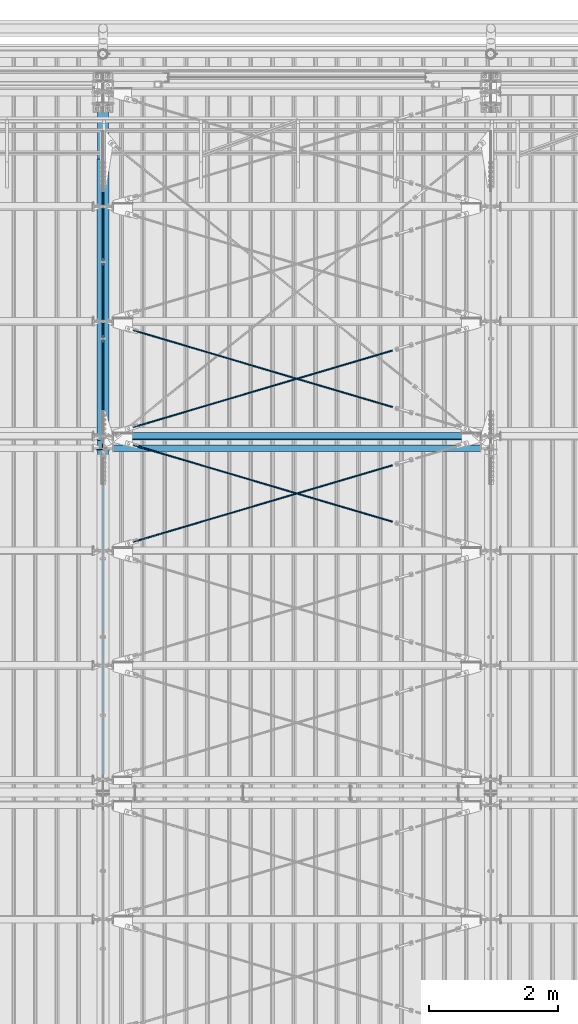
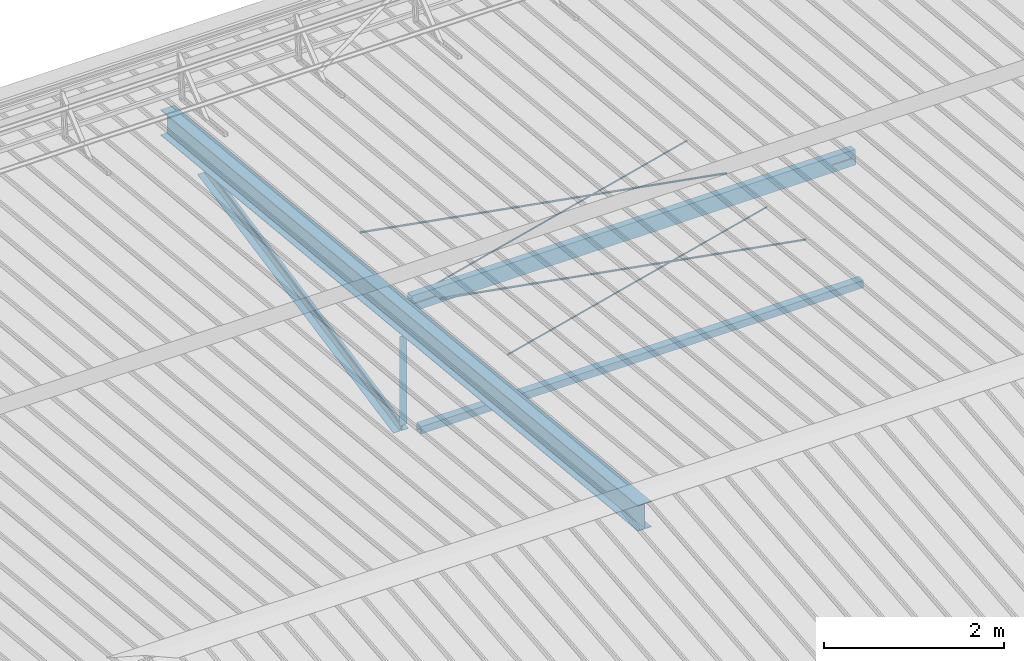
# One storey, part 286 of 709: 10 beams, 6 openings, 10 elements without a shape of their own.
"""IFC4 building model written with IfcOpenShell, lengths in millimetres."""

from ifc_helpers import new_model, si_unit, direction, frame, origin_with_axes, place, context, subcontext, project, spatial, line, indexed_curve, outline, extrude, polygons, material, element, aggregate, save


model = new_model("IFC4")

# Units and contexts
model_context = context("Model", 3, precision=0.2, world=origin_with_axes(), true_north=direction((0.0, 1.0)))
body_context = subcontext(model_context, "Body", "Model", "MODEL_VIEW")
reference_context = subcontext(model_context, "Reference", "Model", "MODEL_VIEW")
ifc_project = project(units=[si_unit("LENGTHUNIT", "METRE", prefix="MILLI"), si_unit("AREAUNIT", "SQUARE_METRE"), si_unit("VOLUMEUNIT", "CUBIC_METRE"), si_unit("MASSUNIT", "GRAM", prefix="KILO"), si_unit("TIMEUNIT", "SECOND"), si_unit("PLANEANGLEUNIT", "RADIAN"), si_unit("SOLIDANGLEUNIT", "STERADIAN"), si_unit("THERMODYNAMICTEMPERATUREUNIT", "DEGREE_CELSIUS"), si_unit("LUMINOUSINTENSITYUNIT", "LUMEN")], contexts=[model_context])

# Site, building, storey
site_placement = place(None, origin_with_axes())
site = spatial("IfcSite", under=ifc_project, at=site_placement, CompositionType="ELEMENT")
building_placement = place(site_placement, origin_with_axes())
building = spatial("IfcBuilding", under=site, at=building_placement, Name="Undefined", CompositionType="ELEMENT")
storey_placement = place(building_placement, origin_with_axes())
storey = spatial("IfcBuildingStorey", under=building, at=storey_placement, Name="Undefined", CompositionType="ELEMENT", Elevation=0.0)

# Assembly, beam
assembly_1_placement = place(storey_placement, frame((40000.0, 21654.0, 7089.70002), z_axis=(-1.0, 0.0, 0.0), x_axis=(0.0, -0.9950371902, 0.099503719)))
assembly_1 = element("IfcElementAssembly", 1, at=assembly_1_placement, inside=storey)
ifc_material_1 = material(Name="C355-5", Category="STEEL")
beam_1_placement = place(assembly_1_placement, origin_with_axes())
beam_1 = element("IfcBeam", 2, at=beam_1_placement, material=ifc_material_1, ObjectType="432", context=body_context, shape_type="Tessellation", body=[
    polygons([(3.80474, -173.0, -87.0), (4.70474, -164.0, -87.0), (10665.6128, -164.0, -87.0), (10664.7128, -173.0, -87.0), (4.70474, -164.0, -3.0), (10665.6128, -164.0, -3.0), (37.50474, 164.0, -3.0), (10698.4128, 164.0, -3.0), (37.50474, 164.0, -87.0), (10698.4128, 164.0, -87.0), (38.40474, 173.0, -87.0), (10699.3128, 173.0, -87.0), (38.40474, 173.0, 87.0), (10699.3128, 173.0, 87.0), (37.50474, 164.0, 87.0), (10698.4128, 164.0, 87.0), (37.50474, 164.0, 3.0), (10698.4128, 164.0, 3.0), (4.70474, -164.0, 3.0), (10665.6128, -164.0, 3.0), (4.70474, -164.0, 87.0), (10665.6128, -164.0, 87.0), (3.80474, -173.0, 87.0), (10664.7128, -173.0, 87.0)], [[[1, 2, 3, 4]], [[2, 5, 6, 3]], [[5, 7, 8, 6]], [[7, 9, 10, 8]], [[9, 11, 12, 10]], [[11, 13, 14, 12]], [[13, 15, 16, 14]], [[15, 17, 18, 16]], [[17, 19, 20, 18]], [[19, 21, 22, 20]], [[21, 23, 24, 22]], [[23, 1, 4, 24]], [[6, 8, 10, 12, 14, 16, 18, 20, 22, 24, 4, 3]], [[23, 21, 19, 17, 15, 13, 11, 9, 7, 5, 2, 1]]], closed=True),
])
aggregate(assembly_1, [beam_1])

assembly_2_placement = place(storey_placement, frame((40051.0, 21649.9404, 7109.99804), z_axis=(0.0, -0.1961161349, 0.9805806757), x_axis=(0.0, -0.9805806757, -0.1961161349)))
assembly_2 = element("IfcElementAssembly", 3, at=assembly_2_placement, inside=storey)
ifc_material_2 = material(Name="C345-5", Category="STEEL")
beam_2_placement = place(assembly_2_placement, origin_with_axes())
beam_2 = element("IfcBeam", 4, at=beam_2_placement, material=ifc_material_2, ObjectType="435", context=body_context, shape_type="Tessellation", body=[
    polygons([(873.96605, -45.0, -45.0), (873.96605, 45.0, -45.0), (5317.375, 45.0, -45.0), (5317.375, -45.0, -45.0), (873.96605, 45.0, -39.0), (5317.375, 45.0, -39.0), (873.96605, -39.0, -39.0), (5317.375, -39.0, -39.0), (873.96605, -39.0, 45.0), (5317.375, -39.0, 45.0), (873.96605, -45.0, 45.0), (5317.375, -45.0, 45.0)], [[[1, 2, 3, 4]], [[2, 5, 6, 3]], [[5, 7, 8, 6]], [[7, 9, 10, 8]], [[9, 11, 12, 10]], [[11, 1, 4, 12]], [[6, 8, 10, 12, 4, 3]], [[11, 9, 7, 5, 2, 1]]], closed=True),
])
aggregate(assembly_2, [beam_2])

assembly_3_placement = place(storey_placement, frame((39949.0, 16322.9404, 6044.59804), z_axis=(0.0, -0.1961161349, 0.9805806757), x_axis=(0.0, 0.9805806757, 0.1961161349)))
assembly_3 = element("IfcElementAssembly", 5, at=assembly_3_placement, inside=storey)
beam_3_placement = place(assembly_3_placement, origin_with_axes())
beam_3 = element("IfcBeam", 6, at=beam_3_placement, material=ifc_material_2, ObjectType="435", context=body_context, shape_type="Tessellation", body=[
    polygons([(115.12039, -45.0, -45.0), (115.12039, 45.0, -45.0), (4558.52934, 45.0, -45.0), (4558.52934, -45.0, -45.0), (115.12039, 45.0, -39.0), (4558.52934, 45.0, -39.0), (115.12039, -39.0, -39.0), (4558.52934, -39.0, -39.0), (115.12039, -39.0, 45.0), (4558.52934, -39.0, 45.0), (115.12039, -45.0, 45.0), (4558.52934, -45.0, 45.0)], [[[1, 2, 3, 4]], [[2, 5, 6, 3]], [[5, 7, 8, 6]], [[7, 9, 10, 8]], [[9, 11, 12, 10]], [[11, 1, 4, 12]], [[6, 8, 10, 12, 4, 3]], [[11, 9, 7, 5, 2, 1]]], closed=True),
])
aggregate(assembly_3, [beam_3])

assembly_4_placement = place(storey_placement, frame((39949.0, 16347.7, 7622.40002), z_axis=(0.0, 1.0, 0.0), x_axis=(0.0, 0.0, -1.0)))
assembly_4 = element("IfcElementAssembly", 7, at=assembly_4_placement, inside=storey)
beam_4_placement = place(assembly_4_placement, origin_with_axes())
beam_4 = element("IfcBeam", 8, at=beam_4_placement, material=ifc_material_2, ObjectType="436", context=body_context, shape_type="Tessellation", body=[
    polygons([(198.6891, -45.0, -45.0), (198.6891, 45.0, -45.0), (1412.4, 45.0, -45.0), (1412.4, -45.0, -45.0), (198.6891, 45.0, -39.0), (1412.4, 45.0, -39.0), (198.6891, -39.0, -39.0), (1412.4, -39.0, -39.0), (198.6891, -39.0, 45.0), (1412.4, -39.0, 45.0), (198.6891, -45.0, 45.0), (1412.4, -45.0, 45.0)], [[[1, 2, 3, 4]], [[2, 5, 6, 3]], [[5, 7, 8, 6]], [[7, 9, 10, 8]], [[9, 11, 12, 10]], [[11, 1, 4, 12]], [[6, 8, 10, 12, 4, 3]], [[11, 9, 7, 5, 2, 1]]], closed=True),
])
aggregate(assembly_4, [beam_4])

assembly_5_placement = place(storey_placement, frame((40000.0, 16327.0, 6074.30002), z_axis=(0.0, -1.0, 0.0), x_axis=(1.0, 0.0, 0.0)))
assembly_5 = element("IfcElementAssembly", 9, at=assembly_5_placement, inside=storey)
ifc_material_3 = material(Name="C355", Category="STEEL")
beam_5_placement = place(assembly_5_placement, origin_with_axes())
beam_5 = element("IfcBeam", 10, at=beam_5_placement, material=ifc_material_3, ObjectType="557", context=body_context, shape_type="Tessellation", body=[
    polygons([(162.0, -47.0, -47.0), (162.0, -47.0, 47.0), (5838.0, -47.0, 47.0), (5838.0, -47.0, -47.0), (162.0, 47.0, 47.0), (5838.0, 47.0, 47.0), (162.0, 47.0, -47.0), (5838.0, 47.0, -47.0), (162.0, -50.0, -50.0), (162.0, 50.0, -50.0), (5838.0, 50.0, -50.0), (5838.0, -50.0, -50.0), (162.0, 50.0, 50.0), (5838.0, 50.0, 50.0), (162.0, -50.0, 50.0), (5838.0, -50.0, 50.0)], [[[1, 2, 3, 4]], [[2, 5, 6, 3]], [[5, 7, 8, 6]], [[7, 1, 4, 8]], [[9, 10, 11, 12]], [[10, 13, 14, 11]], [[13, 15, 16, 14]], [[15, 9, 12, 16]], [[14, 16, 12, 11], [6, 8, 4, 3]], [[15, 13, 10, 9], [7, 5, 2, 1]]], closed=True),
])
aggregate(assembly_5, [beam_5])

# Assembly, beam, voiding feature
assembly_6_placement = place(storey_placement, frame((40000.0, 14737.44615, 7862.7594), z_axis=(0.2847296511, -0.9538504697, 0.095385047), x_axis=(0.9586078582, 0.2833165921, -0.028331659)))
assembly_6 = element("IfcElementAssembly", 11, at=assembly_6_placement, inside=storey)
beam_6_placement = place(assembly_6_placement, origin_with_axes())
beam_6 = element("IfcBeam", 12, at=beam_6_placement, material=ifc_material_1, ObjectType="572", context=body_context, shape_type="Tessellation", body=[
    polygons([(4849.07659, 7.36122, 4.25), (4849.07659, 6.01041, 6.01041), (4849.07659, 4.25, 7.36122), (4849.07659, 2.19996, 8.21037), (4849.07659, 0.0, 8.5), (4849.07659, -2.19996, 8.21037), (4849.07659, -4.25, 7.36122), (4849.07659, -6.01041, 6.01041), (4849.07659, -7.36121, 4.25), (4849.07659, -8.21037, 2.19996), (4849.07659, -8.5, 0.0), (4849.07659, -8.21037, -2.19996), (4849.07659, -7.36121, -4.25), (4849.07659, -6.01041, -6.01041), (4849.07659, -4.25, -7.36122), (4849.07659, -2.19996, -8.21037), (4849.07659, 0.0, -8.5), (4849.07659, 2.19996, -8.21037), (4849.07659, 4.25, -7.36122), (4849.07659, 6.01041, -6.01041), (4849.07659, 7.36122, -4.25), (4849.07659, 8.21037, -2.19996), (4849.07659, 8.5, 0.0), (4849.07659, 8.21037, 2.19996), (4669.07659, 8.21037, 2.19996), (4669.07659, 7.36122, 4.25), (4669.07659, 6.01041, 6.01041), (4669.07659, 4.25, 7.36122), (4669.07659, 2.19996, 8.21037), (4669.07659, 0.0, 8.5), (4669.07659, -2.19996, 8.21037), (4669.07659, -4.25, 7.36122), (4669.07659, -6.01041, 6.01041), (4669.07659, -7.36121, 4.25), (4669.07659, -8.21037, 2.19996), (4669.07659, -8.5, 0.0), (4669.07659, -8.21037, -2.19996), (4669.07659, -7.36121, -4.25), (4669.07659, -6.01041, -6.01041), (4669.07659, -4.25, -7.36122), (4669.07659, -2.19996, -8.21037), (4669.07659, 0.0, -8.5), (4669.07659, 2.19996, -8.21037), (4669.07659, 4.25, -7.36122), (4669.07659, 6.01041, -6.01041), (4669.07659, 7.36122, -4.25), (4669.07659, 8.21037, -2.19996), (4669.07659, 8.5, 0.0), (4669.07659, 10.0, 0.0), (4669.07659, 9.65926, 2.58819), (4669.07659, 8.66025, 5.0), (4669.07659, 7.07107, 7.07107), (4669.07659, 5.0, 8.66025), (4669.07659, 2.58819, 9.65926), (4669.07659, 0.0, 10.0), (4669.07659, -2.58819, 9.65926), (4669.07659, -5.0, 8.66025), (4669.07659, -7.07107, 7.07107), (4669.07659, -8.66025, 5.0), (4669.07659, -9.65926, 2.58819), (4669.07659, -10.0, 0.0), (4669.07659, -9.65926, -2.58819), (4669.07659, -8.66025, -5.0), (4669.07659, -7.07107, -7.07107), (4669.07659, -5.0, -8.66025), (4669.07659, -2.58819, -9.65926), (4669.07659, 0.0, -10.0), (4669.07659, 2.58819, -9.65926), (4669.07659, 5.0, -8.66025), (4669.07659, 7.07107, -7.07107), (4669.07659, 8.66025, -5.0), (4669.07659, 9.65926, -2.58819), (483.68279, 2.58819, 9.65926), (483.68279, 5.0, 8.66025), (483.68279, 7.07107, 7.07107), (483.68279, 8.66025, 5.0), (483.68279, 9.65926, 2.58819), (483.68279, 10.0, 0.0), (483.68279, 9.65926, -2.58819), (483.68279, 8.66025, -5.0), (483.68279, 7.07107, -7.07107), (483.68279, 5.0, -8.66025), (483.68279, 2.58819, -9.65926), (483.68279, 0.0, -10.0), (483.68279, -2.58819, -9.65926), (483.68279, -5.0, -8.66025), (483.68279, -7.07107, -7.07107), (483.68279, -8.66025, -5.0), (483.68279, -9.65926, -2.58819), (483.68279, -10.0, 0.0), (483.68279, -9.65926, 2.58819), (483.68279, -8.66025, 5.0), (483.68279, -7.07107, 7.07107), (483.68279, -5.0, 8.66025), (483.68279, -2.58819, 9.65926), (483.68279, 0.0, 10.0)], [[[1, 2, 3, 4, 5, 6, 7, 8, 9, 10, 11, 12, 13, 14, 15, 16, 17, 18, 19, 20, 21, 22, 23, 24]], [[24, 25, 26, 1]], [[1, 26, 27, 2]], [[2, 27, 28, 3]], [[3, 28, 29, 4]], [[4, 29, 30, 5]], [[5, 30, 31, 6]], [[6, 31, 32, 7]], [[7, 32, 33, 8]], [[8, 33, 34, 9]], [[9, 34, 35, 10]], [[10, 35, 36, 11]], [[11, 36, 37, 12]], [[12, 37, 38, 13]], [[13, 38, 39, 14]], [[14, 39, 40, 15]], [[15, 40, 41, 16]], [[16, 41, 42, 17]], [[17, 42, 43, 18]], [[18, 43, 44, 19]], [[19, 44, 45, 20]], [[20, 45, 46, 21]], [[21, 46, 47, 22]], [[22, 47, 48, 23]], [[23, 48, 25, 24]], [[49, 50, 51, 52, 53, 54, 55, 56, 57, 58, 59, 60, 61, 62, 63, 64, 65, 66, 67, 68, 69, 70, 71, 72], [47, 46, 45, 44, 43, 42, 41, 40, 39, 38, 37, 36, 35, 34, 33, 32, 31, 30, 29, 28, 27, 26, 25, 48]], [[73, 74, 75, 76, 77, 78, 79, 80, 81, 82, 83, 84, 85, 86, 87, 88, 89, 90, 91, 92, 93, 94, 95, 96]], [[79, 78, 49, 72]], [[80, 79, 72, 71]], [[81, 80, 71, 70]], [[82, 81, 70, 69]], [[83, 82, 69, 68]], [[84, 83, 68, 67]], [[85, 84, 67, 66]], [[86, 85, 66, 65]], [[87, 86, 65, 64]], [[88, 87, 64, 63]], [[89, 88, 63, 62]], [[90, 89, 62, 61]], [[91, 90, 61, 60]], [[92, 91, 60, 59]], [[93, 92, 59, 58]], [[94, 93, 58, 57]], [[95, 94, 57, 56]], [[96, 95, 56, 55]], [[73, 96, 55, 54]], [[74, 73, 54, 53]], [[75, 74, 53, 52]], [[76, 75, 52, 51]], [[77, 76, 51, 50]], [[78, 77, 50, 49]]], closed=True),
])
voiding_feature_1_placement = place(beam_6_placement, frame((4849.07659, 0.0, 0.0), z_axis=(0.0, 1.0, 0.0), x_axis=(-1.0, 0.0, 0.0)))
element("IfcVoidingFeature", 13, at=voiding_feature_1_placement, cuts=beam_6, PredefinedType="HOLE", context=reference_context, identifier="Reference", shape_type="SolidModel", body=[
    extrude(outline(indexed_curve([(10.5, 0.0), (10.14222, 2.7176), (9.09327, 5.25), (7.42462, 7.42462), (5.25, 9.09327), (2.7176, 10.14222), (0.0, 10.5), (-2.7176, 10.14222), (-5.25, 9.09327), (-7.42462, 7.42462), (-9.09327, 5.25), (-10.14222, 2.7176), (-10.5, 0.0), (-10.14222, -2.7176), (-9.09327, -5.25), (-7.42462, -7.42462), (-5.25, -9.09327), (-2.7176, -10.14222), (0.0, -10.5), (2.7176, -10.14222), (5.25, -9.09327), (7.42462, -7.42462), (9.09327, -5.25), (10.14222, -2.7176)], segments=[line(1, 2, 3, 4, 5, 6, 7, 8, 9, 10, 11, 12, 13, 14, 15, 16, 17, 18, 19, 20, 21, 22, 23, 24, 1)])), frame((0.0, 0.0, 0.0), z_axis=(-1.0, 0.0, 0.0), x_axis=(0.0, 0.0, 1.0)), (0.0, 0.0, -1.0), 180.0),
])
aggregate(assembly_6, [beam_6])

assembly_7_placement = place(storey_placement, frame((40000.0, 16510.7464, 7685.42938), z_axis=(-0.2847296511, -0.9538504697, 0.095385047), x_axis=(0.9586078582, -0.2833165921, 0.028331659)))
assembly_7 = element("IfcElementAssembly", 14, at=assembly_7_placement, inside=storey)
beam_7_placement = place(assembly_7_placement, origin_with_axes())
beam_7 = element("IfcBeam", 15, at=beam_7_placement, material=ifc_material_1, ObjectType="572", context=body_context, shape_type="Tessellation", body=[
    polygons([(4849.07659, 7.36122, 4.25), (4849.07659, 6.01041, 6.01041), (4849.07659, 4.25, 7.36122), (4849.07659, 2.19996, 8.21037), (4849.07659, 0.0, 8.5), (4849.07659, -2.19996, 8.21037), (4849.07659, -4.25, 7.36122), (4849.07659, -6.01041, 6.01041), (4849.07659, -7.36121, 4.25), (4849.07659, -8.21037, 2.19996), (4849.07659, -8.5, 0.0), (4849.07659, -8.21037, -2.19996), (4849.07659, -7.36121, -4.25), (4849.07659, -6.01041, -6.01041), (4849.07659, -4.25, -7.36122), (4849.07659, -2.19996, -8.21037), (4849.07659, 0.0, -8.5), (4849.07659, 2.19996, -8.21037), (4849.07659, 4.25, -7.36122), (4849.07659, 6.01041, -6.01041), (4849.07659, 7.36122, -4.25), (4849.07659, 8.21037, -2.19996), (4849.07659, 8.5, 0.0), (4849.07659, 8.21037, 2.19996), (4669.07659, 8.21037, 2.19996), (4669.07659, 7.36122, 4.25), (4669.07659, 6.01041, 6.01041), (4669.07659, 4.25, 7.36122), (4669.07659, 2.19996, 8.21037), (4669.07659, 0.0, 8.5), (4669.07659, -2.19996, 8.21037), (4669.07659, -4.25, 7.36122), (4669.07659, -6.01041, 6.01041), (4669.07659, -7.36121, 4.25), (4669.07659, -8.21037, 2.19996), (4669.07659, -8.5, 0.0), (4669.07659, -8.21037, -2.19996), (4669.07659, -7.36121, -4.25), (4669.07659, -6.01041, -6.01041), (4669.07659, -4.25, -7.36122), (4669.07659, -2.19996, -8.21037), (4669.07659, 0.0, -8.5), (4669.07659, 2.19996, -8.21037), (4669.07659, 4.25, -7.36122), (4669.07659, 6.01041, -6.01041), (4669.07659, 7.36122, -4.25), (4669.07659, 8.21037, -2.19996), (4669.07659, 8.5, 0.0), (4669.07659, 10.0, 0.0), (4669.07659, 9.65926, 2.58819), (4669.07659, 8.66025, 5.0), (4669.07659, 7.07107, 7.07107), (4669.07659, 5.0, 8.66025), (4669.07659, 2.58819, 9.65926), (4669.07659, 0.0, 10.0), (4669.07659, -2.58819, 9.65926), (4669.07659, -5.0, 8.66025), (4669.07659, -7.07107, 7.07107), (4669.07659, -8.66025, 5.0), (4669.07659, -9.65926, 2.58819), (4669.07659, -10.0, 0.0), (4669.07659, -9.65926, -2.58819), (4669.07659, -8.66025, -5.0), (4669.07659, -7.07107, -7.07107), (4669.07659, -5.0, -8.66025), (4669.07659, -2.58819, -9.65926), (4669.07659, 0.0, -10.0), (4669.07659, 2.58819, -9.65926), (4669.07659, 5.0, -8.66025), (4669.07659, 7.07107, -7.07107), (4669.07659, 8.66025, -5.0), (4669.07659, 9.65926, -2.58819), (483.68279, 2.58819, 9.65926), (483.68279, 5.0, 8.66025), (483.68279, 7.07107, 7.07107), (483.68279, 8.66025, 5.0), (483.68279, 9.65926, 2.58819), (483.68279, 10.0, 0.0), (483.68279, 9.65926, -2.58819), (483.68279, 8.66025, -5.0), (483.68279, 7.07107, -7.07107), (483.68279, 5.0, -8.66025), (483.68279, 2.58819, -9.65926), (483.68279, 0.0, -10.0), (483.68279, -2.58819, -9.65926), (483.68279, -5.0, -8.66025), (483.68279, -7.07107, -7.07107), (483.68279, -8.66025, -5.0), (483.68279, -9.65926, -2.58819), (483.68279, -10.0, 0.0), (483.68279, -9.65926, 2.58819), (483.68279, -8.66025, 5.0), (483.68279, -7.07107, 7.07107), (483.68279, -5.0, 8.66025), (483.68279, -2.58819, 9.65926), (483.68279, 0.0, 10.0)], [[[1, 2, 3, 4, 5, 6, 7, 8, 9, 10, 11, 12, 13, 14, 15, 16, 17, 18, 19, 20, 21, 22, 23, 24]], [[24, 25, 26, 1]], [[1, 26, 27, 2]], [[2, 27, 28, 3]], [[3, 28, 29, 4]], [[4, 29, 30, 5]], [[5, 30, 31, 6]], [[6, 31, 32, 7]], [[7, 32, 33, 8]], [[8, 33, 34, 9]], [[9, 34, 35, 10]], [[10, 35, 36, 11]], [[11, 36, 37, 12]], [[12, 37, 38, 13]], [[13, 38, 39, 14]], [[14, 39, 40, 15]], [[15, 40, 41, 16]], [[16, 41, 42, 17]], [[17, 42, 43, 18]], [[18, 43, 44, 19]], [[19, 44, 45, 20]], [[20, 45, 46, 21]], [[21, 46, 47, 22]], [[22, 47, 48, 23]], [[23, 48, 25, 24]], [[49, 50, 51, 52, 53, 54, 55, 56, 57, 58, 59, 60, 61, 62, 63, 64, 65, 66, 67, 68, 69, 70, 71, 72], [47, 46, 45, 44, 43, 42, 41, 40, 39, 38, 37, 36, 35, 34, 33, 32, 31, 30, 29, 28, 27, 26, 25, 48]], [[73, 74, 75, 76, 77, 78, 79, 80, 81, 82, 83, 84, 85, 86, 87, 88, 89, 90, 91, 92, 93, 94, 95, 96]], [[79, 78, 49, 72]], [[80, 79, 72, 71]], [[81, 80, 71, 70]], [[82, 81, 70, 69]], [[83, 82, 69, 68]], [[84, 83, 68, 67]], [[85, 84, 67, 66]], [[86, 85, 66, 65]], [[87, 86, 65, 64]], [[88, 87, 64, 63]], [[89, 88, 63, 62]], [[90, 89, 62, 61]], [[91, 90, 61, 60]], [[92, 91, 60, 59]], [[93, 92, 59, 58]], [[94, 93, 58, 57]], [[95, 94, 57, 56]], [[96, 95, 56, 55]], [[73, 96, 55, 54]], [[74, 73, 54, 53]], [[75, 74, 53, 52]], [[76, 75, 52, 51]], [[77, 76, 51, 50]], [[78, 77, 50, 49]]], closed=True),
])
voiding_feature_2_placement = place(beam_7_placement, frame((4849.07659, 0.0, 0.0), z_axis=(0.0, 1.0, 0.0), x_axis=(-1.0, 0.0, 0.0)))
element("IfcVoidingFeature", 16, at=voiding_feature_2_placement, cuts=beam_7, PredefinedType="HOLE", context=reference_context, identifier="Reference", shape_type="SolidModel", body=[
    extrude(outline(indexed_curve([(10.5, 0.0), (10.14222, 2.7176), (9.09327, 5.25), (7.42462, 7.42462), (5.25, 9.09327), (2.7176, 10.14222), (0.0, 10.5), (-2.7176, 10.14222), (-5.25, 9.09327), (-7.42462, 7.42462), (-9.09327, 5.25), (-10.14222, 2.7176), (-10.5, 0.0), (-10.14222, -2.7176), (-9.09327, -5.25), (-7.42462, -7.42462), (-5.25, -9.09327), (-2.7176, -10.14222), (0.0, -10.5), (2.7176, -10.14222), (5.25, -9.09327), (7.42462, -7.42462), (9.09327, -5.25), (10.14222, -2.7176)], segments=[line(1, 2, 3, 4, 5, 6, 7, 8, 9, 10, 11, 12, 13, 14, 15, 16, 17, 18, 19, 20, 21, 22, 23, 24, 1)])), frame((0.0, 0.0, 0.0), z_axis=(-1.0, 0.0, 0.0), x_axis=(0.0, 0.0, 1.0)), (0.0, 0.0, -1.0), 180.0),
])
aggregate(assembly_7, [beam_7])

assembly_8_placement = place(storey_placement, frame((40000.0, 16510.7464, 7685.42938), z_axis=(0.2852311229, -0.9537021177, 0.0953702118), x_axis=(0.9584587662, 0.2838155751, -0.028381558)))
assembly_8 = element("IfcElementAssembly", 17, at=assembly_8_placement, inside=storey)
beam_8_placement = place(assembly_8_placement, origin_with_axes())
beam_8 = element("IfcBeam", 18, at=beam_8_placement, material=ifc_material_1, ObjectType="570", context=body_context, shape_type="Tessellation", body=[
    polygons([(4850.05021, 7.36122, 4.25), (4850.05021, 6.01041, 6.01041), (4850.05021, 4.25, 7.36121), (4850.05021, 2.19996, 8.21037), (4850.05021, 0.0, 8.5), (4850.05021, -2.19996, 8.21037), (4850.05021, -4.25, 7.36121), (4850.05021, -6.01041, 6.01041), (4850.05021, -7.36121, 4.25), (4850.05021, -8.21037, 2.19996), (4850.05021, -8.5, 0.0), (4850.05021, -8.21037, -2.19996), (4850.05021, -7.36121, -4.25), (4850.05021, -6.01041, -6.01041), (4850.05021, -4.25, -7.36122), (4850.05021, -2.19996, -8.21037), (4850.05021, 0.0, -8.5), (4850.05021, 2.19996, -8.21037), (4850.05021, 4.25, -7.36122), (4850.05021, 6.01041, -6.01041), (4850.05021, 7.36122, -4.25), (4850.05021, 8.21037, -2.19996), (4850.05021, 8.5, 0.0), (4850.05021, 8.21037, 2.19996), (4670.05021, 8.21037, 2.19996), (4670.05021, 7.36122, 4.25), (4670.05021, 6.01041, 6.01041), (4670.05021, 4.25, 7.36121), (4670.05021, 2.19996, 8.21037), (4670.05021, 0.0, 8.5), (4670.05021, -2.19996, 8.21037), (4670.05021, -4.25, 7.36121), (4670.05021, -6.01041, 6.01041), (4670.05021, -7.36121, 4.25), (4670.05021, -8.21037, 2.19996), (4670.05021, -8.5, 0.0), (4670.05021, -8.21037, -2.19996), (4670.05021, -7.36121, -4.25), (4670.05021, -6.01041, -6.01041), (4670.05021, -4.25, -7.36122), (4670.05021, -2.19996, -8.21037), (4670.05021, 0.0, -8.5), (4670.05021, 2.19996, -8.21037), (4670.05021, 4.25, -7.36122), (4670.05021, 6.01041, -6.01041), (4670.05021, 7.36122, -4.25), (4670.05021, 8.21037, -2.19996), (4670.05021, 8.5, 0.0), (4670.05021, 10.0, 0.0), (4670.05021, 9.65926, 2.58819), (4670.05021, 8.66025, 5.0), (4670.05021, 7.07107, 7.07107), (4670.05021, 5.0, 8.66025), (4670.05021, 2.58819, 9.65926), (4670.05021, 0.0, 10.0), (4670.05021, -2.58819, 9.65926), (4670.05021, -5.0, 8.66025), (4670.05021, -7.07107, 7.07107), (4670.05021, -8.66025, 5.0), (4670.05021, -9.65926, 2.58819), (4670.05021, -10.0, 0.0), (4670.05021, -9.65926, -2.58819), (4670.05021, -8.66025, -5.0), (4670.05021, -7.07107, -7.07107), (4670.05021, -5.0, -8.66025), (4670.05021, -2.58819, -9.65926), (4670.05021, 0.0, -10.0), (4670.05021, 2.58819, -9.65926), (4670.05021, 5.0, -8.66025), (4670.05021, 7.07107, -7.07107), (4670.05021, 8.66025, -5.0), (4670.05021, 9.65926, -2.58819), (483.0251, 2.58819, 9.65926), (483.0251, 5.0, 8.66025), (483.0251, 7.07107, 7.07107), (483.0251, 8.66025, 5.0), (483.0251, 9.65926, 2.58819), (483.0251, 10.0, 0.0), (483.0251, 9.65926, -2.58819), (483.0251, 8.66025, -5.0), (483.0251, 7.07107, -7.07107), (483.0251, 5.0, -8.66025), (483.0251, 2.58819, -9.65926), (483.0251, 0.0, -10.0), (483.0251, -2.58819, -9.65926), (483.0251, -5.0, -8.66025), (483.0251, -7.07107, -7.07107), (483.0251, -8.66025, -5.0), (483.0251, -9.65926, -2.58819), (483.0251, -10.0, 0.0), (483.0251, -9.65926, 2.58819), (483.0251, -8.66025, 5.0), (483.0251, -7.07107, 7.07107), (483.0251, -5.0, 8.66025), (483.0251, -2.58819, 9.65926), (483.0251, 0.0, 10.0)], [[[1, 2, 3, 4, 5, 6, 7, 8, 9, 10, 11, 12, 13, 14, 15, 16, 17, 18, 19, 20, 21, 22, 23, 24]], [[24, 25, 26, 1]], [[1, 26, 27, 2]], [[2, 27, 28, 3]], [[3, 28, 29, 4]], [[4, 29, 30, 5]], [[5, 30, 31, 6]], [[6, 31, 32, 7]], [[7, 32, 33, 8]], [[8, 33, 34, 9]], [[9, 34, 35, 10]], [[10, 35, 36, 11]], [[11, 36, 37, 12]], [[12, 37, 38, 13]], [[13, 38, 39, 14]], [[14, 39, 40, 15]], [[15, 40, 41, 16]], [[16, 41, 42, 17]], [[17, 42, 43, 18]], [[18, 43, 44, 19]], [[19, 44, 45, 20]], [[20, 45, 46, 21]], [[21, 46, 47, 22]], [[22, 47, 48, 23]], [[23, 48, 25, 24]], [[49, 50, 51, 52, 53, 54, 55, 56, 57, 58, 59, 60, 61, 62, 63, 64, 65, 66, 67, 68, 69, 70, 71, 72], [47, 46, 45, 44, 43, 42, 41, 40, 39, 38, 37, 36, 35, 34, 33, 32, 31, 30, 29, 28, 27, 26, 25, 48]], [[73, 74, 75, 76, 77, 78, 79, 80, 81, 82, 83, 84, 85, 86, 87, 88, 89, 90, 91, 92, 93, 94, 95, 96]], [[79, 78, 49, 72]], [[80, 79, 72, 71]], [[81, 80, 71, 70]], [[82, 81, 70, 69]], [[83, 82, 69, 68]], [[84, 83, 68, 67]], [[85, 84, 67, 66]], [[86, 85, 66, 65]], [[87, 86, 65, 64]], [[88, 87, 64, 63]], [[89, 88, 63, 62]], [[90, 89, 62, 61]], [[91, 90, 61, 60]], [[92, 91, 60, 59]], [[93, 92, 59, 58]], [[94, 93, 58, 57]], [[95, 94, 57, 56]], [[96, 95, 56, 55]], [[73, 96, 55, 54]], [[74, 73, 54, 53]], [[75, 74, 53, 52]], [[76, 75, 52, 51]], [[77, 76, 51, 50]], [[78, 77, 50, 49]]], closed=True),
])
voiding_feature_3_placement = place(beam_8_placement, frame((4850.05021, 0.0, 0.0), z_axis=(0.0, 1.0, 0.0), x_axis=(-1.0, 0.0, 0.0)))
element("IfcVoidingFeature", 19, at=voiding_feature_3_placement, cuts=beam_8, PredefinedType="HOLE", context=reference_context, identifier="Reference", shape_type="SolidModel", body=[
    extrude(outline(indexed_curve([(10.5, 0.0), (10.14222, 2.7176), (9.09327, 5.25), (7.42462, 7.42462), (5.25, 9.09327), (2.7176, 10.14222), (0.0, 10.5), (-2.7176, 10.14222), (-5.25, 9.09327), (-7.42462, 7.42462), (-9.09327, 5.25), (-10.14222, 2.7176), (-10.5, 0.0), (-10.14222, -2.7176), (-9.09327, -5.25), (-7.42462, -7.42462), (-5.25, -9.09327), (-2.7176, -10.14222), (0.0, -10.5), (2.7176, -10.14222), (5.25, -9.09327), (7.42462, -7.42462), (9.09327, -5.25), (10.14222, -2.7176)], segments=[line(1, 2, 3, 4, 5, 6, 7, 8, 9, 10, 11, 12, 13, 14, 15, 16, 17, 18, 19, 20, 21, 22, 23, 24, 1)])), frame((0.0, 0.0, 0.0), z_axis=(-1.0, 0.0, 0.0), x_axis=(0.0, 0.0, 1.0)), (0.0, 0.0, -1.0), 180.0),
])
aggregate(assembly_8, [beam_8])

assembly_9_placement = place(storey_placement, frame((40000.0, 18287.44615, 7507.7594), z_axis=(-0.2852311229, -0.9537021177, 0.0953702118), x_axis=(0.9584587662, -0.2838155751, 0.028381558)))
assembly_9 = element("IfcElementAssembly", 20, at=assembly_9_placement, inside=storey)
beam_9_placement = place(assembly_9_placement, origin_with_axes())
beam_9 = element("IfcBeam", 21, at=beam_9_placement, material=ifc_material_1, ObjectType="570", context=body_context, shape_type="Tessellation", body=[
    polygons([(4850.05021, 7.36122, 4.25), (4850.05021, 6.01041, 6.01041), (4850.05021, 4.25, 7.36121), (4850.05021, 2.19996, 8.21037), (4850.05021, 0.0, 8.5), (4850.05021, -2.19996, 8.21037), (4850.05021, -4.25, 7.36121), (4850.05021, -6.01041, 6.01041), (4850.05021, -7.36121, 4.25), (4850.05021, -8.21037, 2.19996), (4850.05021, -8.5, 0.0), (4850.05021, -8.21037, -2.19996), (4850.05021, -7.36121, -4.25), (4850.05021, -6.01041, -6.01041), (4850.05021, -4.25, -7.36122), (4850.05021, -2.19996, -8.21037), (4850.05021, 0.0, -8.5), (4850.05021, 2.19996, -8.21037), (4850.05021, 4.25, -7.36122), (4850.05021, 6.01041, -6.01041), (4850.05021, 7.36122, -4.25), (4850.05021, 8.21037, -2.19996), (4850.05021, 8.5, 0.0), (4850.05021, 8.21037, 2.19996), (4670.05021, 8.21037, 2.19996), (4670.05021, 7.36122, 4.25), (4670.05021, 6.01041, 6.01041), (4670.05021, 4.25, 7.36121), (4670.05021, 2.19996, 8.21037), (4670.05021, 0.0, 8.5), (4670.05021, -2.19996, 8.21037), (4670.05021, -4.25, 7.36121), (4670.05021, -6.01041, 6.01041), (4670.05021, -7.36121, 4.25), (4670.05021, -8.21037, 2.19996), (4670.05021, -8.5, 0.0), (4670.05021, -8.21037, -2.19996), (4670.05021, -7.36121, -4.25), (4670.05021, -6.01041, -6.01041), (4670.05021, -4.25, -7.36122), (4670.05021, -2.19996, -8.21037), (4670.05021, 0.0, -8.5), (4670.05021, 2.19996, -8.21037), (4670.05021, 4.25, -7.36122), (4670.05021, 6.01041, -6.01041), (4670.05021, 7.36122, -4.25), (4670.05021, 8.21037, -2.19996), (4670.05021, 8.5, 0.0), (4670.05021, 10.0, 0.0), (4670.05021, 9.65926, 2.58819), (4670.05021, 8.66025, 5.0), (4670.05021, 7.07107, 7.07107), (4670.05021, 5.0, 8.66025), (4670.05021, 2.58819, 9.65926), (4670.05021, 0.0, 10.0), (4670.05021, -2.58819, 9.65926), (4670.05021, -5.0, 8.66025), (4670.05021, -7.07107, 7.07107), (4670.05021, -8.66025, 5.0), (4670.05021, -9.65926, 2.58819), (4670.05021, -10.0, 0.0), (4670.05021, -9.65926, -2.58819), (4670.05021, -8.66025, -5.0), (4670.05021, -7.07107, -7.07107), (4670.05021, -5.0, -8.66025), (4670.05021, -2.58819, -9.65926), (4670.05021, 0.0, -10.0), (4670.05021, 2.58819, -9.65926), (4670.05021, 5.0, -8.66025), (4670.05021, 7.07107, -7.07107), (4670.05021, 8.66025, -5.0), (4670.05021, 9.65926, -2.58819), (483.0251, 2.58819, 9.65926), (483.0251, 5.0, 8.66025), (483.0251, 7.07107, 7.07107), (483.0251, 8.66025, 5.0), (483.0251, 9.65926, 2.58819), (483.0251, 10.0, 0.0), (483.0251, 9.65926, -2.58819), (483.0251, 8.66025, -5.0), (483.0251, 7.07107, -7.07107), (483.0251, 5.0, -8.66025), (483.0251, 2.58819, -9.65926), (483.0251, 0.0, -10.0), (483.0251, -2.58819, -9.65926), (483.0251, -5.0, -8.66025), (483.0251, -7.07107, -7.07107), (483.0251, -8.66025, -5.0), (483.0251, -9.65926, -2.58819), (483.0251, -10.0, 0.0), (483.0251, -9.65926, 2.58819), (483.0251, -8.66025, 5.0), (483.0251, -7.07107, 7.07107), (483.0251, -5.0, 8.66025), (483.0251, -2.58819, 9.65926), (483.0251, 0.0, 10.0)], [[[1, 2, 3, 4, 5, 6, 7, 8, 9, 10, 11, 12, 13, 14, 15, 16, 17, 18, 19, 20, 21, 22, 23, 24]], [[24, 25, 26, 1]], [[1, 26, 27, 2]], [[2, 27, 28, 3]], [[3, 28, 29, 4]], [[4, 29, 30, 5]], [[5, 30, 31, 6]], [[6, 31, 32, 7]], [[7, 32, 33, 8]], [[8, 33, 34, 9]], [[9, 34, 35, 10]], [[10, 35, 36, 11]], [[11, 36, 37, 12]], [[12, 37, 38, 13]], [[13, 38, 39, 14]], [[14, 39, 40, 15]], [[15, 40, 41, 16]], [[16, 41, 42, 17]], [[17, 42, 43, 18]], [[18, 43, 44, 19]], [[19, 44, 45, 20]], [[20, 45, 46, 21]], [[21, 46, 47, 22]], [[22, 47, 48, 23]], [[23, 48, 25, 24]], [[49, 50, 51, 52, 53, 54, 55, 56, 57, 58, 59, 60, 61, 62, 63, 64, 65, 66, 67, 68, 69, 70, 71, 72], [47, 46, 45, 44, 43, 42, 41, 40, 39, 38, 37, 36, 35, 34, 33, 32, 31, 30, 29, 28, 27, 26, 25, 48]], [[73, 74, 75, 76, 77, 78, 79, 80, 81, 82, 83, 84, 85, 86, 87, 88, 89, 90, 91, 92, 93, 94, 95, 96]], [[79, 78, 49, 72]], [[80, 79, 72, 71]], [[81, 80, 71, 70]], [[82, 81, 70, 69]], [[83, 82, 69, 68]], [[84, 83, 68, 67]], [[85, 84, 67, 66]], [[86, 85, 66, 65]], [[87, 86, 65, 64]], [[88, 87, 64, 63]], [[89, 88, 63, 62]], [[90, 89, 62, 61]], [[91, 90, 61, 60]], [[92, 91, 60, 59]], [[93, 92, 59, 58]], [[94, 93, 58, 57]], [[95, 94, 57, 56]], [[96, 95, 56, 55]], [[73, 96, 55, 54]], [[74, 73, 54, 53]], [[75, 74, 53, 52]], [[76, 75, 52, 51]], [[77, 76, 51, 50]], [[78, 77, 50, 49]]], closed=True),
])
voiding_feature_4_placement = place(beam_9_placement, frame((4850.05021, 0.0, 0.0), z_axis=(0.0, 1.0, 0.0), x_axis=(-1.0, 0.0, 0.0)))
element("IfcVoidingFeature", 22, at=voiding_feature_4_placement, cuts=beam_9, PredefinedType="HOLE", context=reference_context, identifier="Reference", shape_type="SolidModel", body=[
    extrude(outline(indexed_curve([(10.5, 0.0), (10.14222, 2.7176), (9.09327, 5.25), (7.42462, 7.42462), (5.25, 9.09327), (2.7176, 10.14222), (0.0, 10.5), (-2.7176, 10.14222), (-5.25, 9.09327), (-7.42462, 7.42462), (-9.09327, 5.25), (-10.14222, 2.7176), (-10.5, 0.0), (-10.14222, -2.7176), (-9.09327, -5.25), (-7.42462, -7.42462), (-5.25, -9.09327), (-2.7176, -10.14222), (0.0, -10.5), (2.7176, -10.14222), (5.25, -9.09327), (7.42462, -7.42462), (9.09327, -5.25), (10.14222, -2.7176)], segments=[line(1, 2, 3, 4, 5, 6, 7, 8, 9, 10, 11, 12, 13, 14, 15, 16, 17, 18, 19, 20, 21, 22, 23, 24, 1)])), frame((0.0, 0.0, 0.0), z_axis=(-1.0, 0.0, 0.0), x_axis=(0.0, 0.0, 1.0)), (0.0, 0.0, -1.0), 180.0),
])
aggregate(assembly_9, [beam_9])

# Assembly, beam, voiding features
assembly_10_placement = place(storey_placement, frame((46000.0, 16509.95037, 7677.46908), z_axis=(0.0, -0.9950371902, 0.099503719), x_axis=(-1.0, 0.0, 0.0)))
assembly_10 = element("IfcElementAssembly", 23, at=assembly_10_placement, inside=storey)
beam_10_placement = place(assembly_10_placement, origin_with_axes())
beam_10 = element("IfcBeam", 24, at=beam_10_placement, material=ifc_material_3, ObjectType="566", context=body_context, shape_type="Tessellation", body=[
    polygons([(457.15477, -5.0, 50.0), (457.13954, -5.0, 46.0), (155.0, -5.0, 46.0), (155.0, -5.0, 50.0), (457.15477, 5.0, 50.0), (457.13954, 5.0, 46.0), (155.0, 5.0, 50.0), (155.0, 5.0, 46.0), (456.78932, -5.0, -46.0), (456.77409, -5.0, -50.0), (155.0, -5.0, -50.0), (155.0, -5.0, -46.0), (456.78932, 5.0, -46.0), (456.77409, 5.0, -50.0), (155.0, 5.0, -46.0), (155.0, 5.0, -50.0), (155.0, 96.0, 46.0), (155.0, 96.0, -46.0), (5845.0, 96.0, -46.0), (5845.0, 96.0, 46.0), (155.0, 100.0, -50.0), (5845.0, 100.0, -50.0), (5845.0, 5.0, -50.0), (5543.2259, 5.0, -50.0), (5543.2259, -5.0, -50.0), (5845.0, -5.0, -50.0), (5845.0, -100.0, -50.0), (155.0, -100.0, -50.0), (5845.00055, 5.0, -46.0), (5543.21068, 5.0, -46.0), (5543.21068, -5.0, -46.0), (5845.0, -5.0, -46.0), (155.0, -96.0, -46.0), (155.0, -96.0, 46.0), (5845.0, -96.0, 46.0), (5845.0, -96.0, -46.0), (5542.84523, -5.0, 50.0), (5542.86046, -5.0, 46.0), (5542.86046, 5.0, 46.0), (5542.84523, 5.0, 50.0), (5845.0, -5.0, 50.0), (5845.0, -5.0, 46.0), (5845.0, -100.0, 50.0), (155.0, -100.0, 50.0), (5845.0, 5.0, 46.0), (5845.00055, 5.0, 50.0), (5845.0, 100.0, 50.0), (155.0, 100.0, 50.0)], [[[1, 2, 3, 4]], [[5, 6, 2, 1]], [[7, 8, 6, 5]], [[9, 10, 11, 12]], [[13, 14, 10, 9]], [[15, 16, 14, 13]], [[17, 18, 19, 20]], [[21, 22, 23, 24, 25, 26, 27, 28, 11, 10, 14, 16]], [[29, 30, 24, 23]], [[31, 25, 24, 30]], [[32, 26, 25, 31]], [[33, 34, 35, 36]], [[37, 38, 39, 40]], [[41, 42, 38, 37]], [[43, 27, 26, 32, 36, 35, 42, 41]], [[44, 28, 27, 43]], [[34, 33, 12, 11, 28, 44, 4, 3]], [[17, 20, 45, 39, 38, 42, 35, 34, 3, 2, 6, 8]], [[46, 40, 39, 45]], [[20, 19, 29, 23, 22, 47, 46, 45]], [[21, 48, 47, 22]], [[4, 44, 43, 41, 37, 40, 46, 47, 48, 7, 5, 1]], [[48, 21, 16, 15, 18, 17, 8, 7]], [[12, 33, 36, 32, 31, 30, 29, 19, 18, 15, 13, 9]]], closed=True),
])
voiding_feature_5_placement = place(beam_10_placement, frame((5845.00055, 0.0, -93.07721), z_axis=(0.0, -1.0, 0.0), x_axis=(0.0, 0.0, 1.0)))
element("IfcVoidingFeature", 25, at=voiding_feature_5_placement, cuts=beam_10, Name="PLATE", PredefinedType="HOLE", context=reference_context, identifier="Reference", shape_type="SolidModel", body=[
    extrude(outline(indexed_curve([(0.0, 0.0), (186.05886, 0.0), (268.2388, 276.67769), (181.9641, 302.30336), (4.13868, 301.62642), (-82.1226, 275.95562)], segments=[line(1, 2, 3, 4, 5, 6, 1)])), frame((0.0, 0.0, 5.0), z_axis=(0.0, 0.0, 1.0), x_axis=(1.0, 0.0, 0.0)), (0.0, 0.0, -1.0), 10.0),
])
voiding_feature_6_placement = place(beam_10_placement, frame((154.99945, 0.0, 92.98165), z_axis=(0.0, -1.0, 0.0), x_axis=(0.0, 0.0, -1.0)))
element("IfcVoidingFeature", 26, at=voiding_feature_6_placement, cuts=beam_10, Name="PLATE", PredefinedType="HOLE", context=reference_context, identifier="Reference", shape_type="SolidModel", body=[
    extrude(outline(indexed_curve([(0.0, 0.0), (186.05886, 0.0), (268.18146, 275.95562), (181.92017, 301.62642), (4.09476, 302.30336), (-82.17995, 276.67769)], segments=[line(1, 2, 3, 4, 5, 6, 1)])), frame((0.0, 0.0, 5.0), z_axis=(0.0, 0.0, 1.0), x_axis=(1.0, 0.0, 0.0)), (0.0, 0.0, -1.0), 10.0),
])
aggregate(assembly_10, [beam_10])

save(model, "model.ifc")
